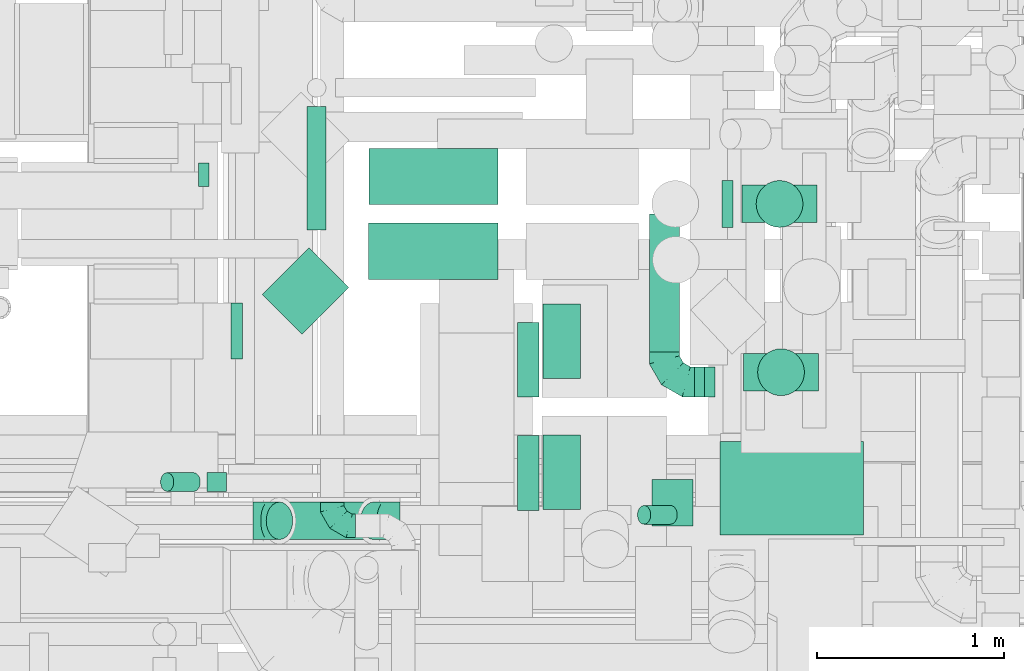
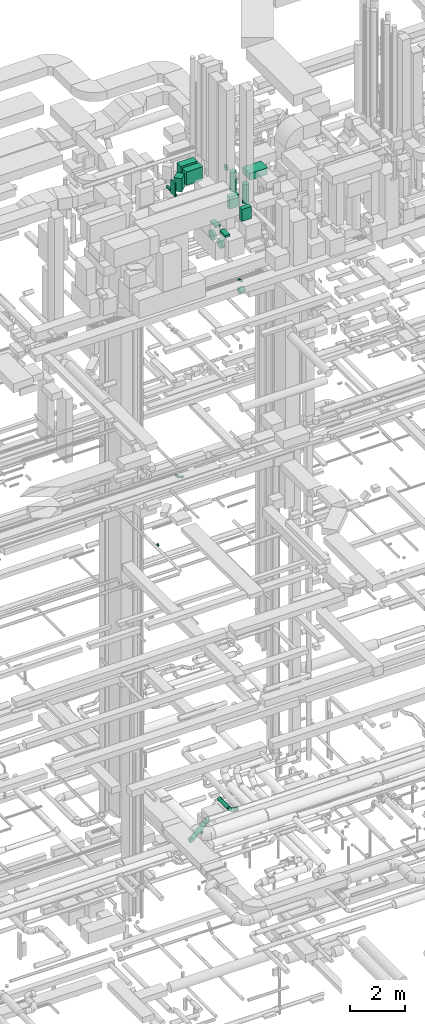
# One storey, part 181 of 337: 23 flow segments, 5 flow fittings.
"""IFC2X3 building model written with IfcOpenShell, lengths in millimetres."""

from ifc_helpers import new_model, entity, si_unit, converted_unit, derived_unit, direction, frame, origin, origin_2d_with_axis, place, context, subcontext, project, spatial, rectangle, circle, extrude, faceted_brep, source, transform, mapped, material, type_object, type_shapes, element, save


model = new_model("IFC2X3")

# Units and contexts
model_context = context("Model", 3, precision=0.01, world=origin(), true_north=direction((6.12303176911189e-17, 1.0)))
body_context = subcontext(model_context, "Body", "Model", "MODEL_VIEW")
ifc_project = project(units=[si_unit("LENGTHUNIT", "METRE", prefix="MILLI"), si_unit("AREAUNIT", "SQUARE_METRE"), si_unit("VOLUMEUNIT", "CUBIC_METRE"), converted_unit("PLANEANGLEUNIT", "DEGREE", entity("IfcRatioMeasure", 0.0174532925199433), si_unit("PLANEANGLEUNIT", "RADIAN"), dimensions=[0, 0, 0, 0, 0, 0, 0]), si_unit("MASSUNIT", "GRAM", prefix="KILO"), derived_unit("MASSDENSITYUNIT", [(si_unit("MASSUNIT", "GRAM", prefix="KILO"), 1), (si_unit("LENGTHUNIT", "METRE"), -3)]), derived_unit("MOMENTOFINERTIAUNIT", [(si_unit("LENGTHUNIT", "METRE"), 4)]), si_unit("TIMEUNIT", "SECOND"), si_unit("FREQUENCYUNIT", "HERTZ"), si_unit("THERMODYNAMICTEMPERATUREUNIT", "DEGREE_CELSIUS"), derived_unit("THERMALTRANSMITTANCEUNIT", [(si_unit("MASSUNIT", "GRAM", prefix="KILO"), 1), (si_unit("THERMODYNAMICTEMPERATUREUNIT", "KELVIN"), -1), (si_unit("TIMEUNIT", "SECOND"), -3)]), derived_unit("VOLUMETRICFLOWRATEUNIT", [(si_unit("LENGTHUNIT", "METRE"), 3), (si_unit("TIMEUNIT", "SECOND"), -1)]), derived_unit("MASSFLOWRATEUNIT", [(si_unit("MASSUNIT", "GRAM", prefix="KILO"), 1), (si_unit("TIMEUNIT", "SECOND"), -1)]), derived_unit("ROTATIONALFREQUENCYUNIT", [(si_unit("TIMEUNIT", "SECOND"), -1)]), si_unit("ELECTRICCURRENTUNIT", "AMPERE"), si_unit("ELECTRICVOLTAGEUNIT", "VOLT"), si_unit("POWERUNIT", "WATT"), si_unit("FORCEUNIT", "NEWTON", prefix="KILO"), si_unit("ILLUMINANCEUNIT", "LUX"), si_unit("LUMINOUSFLUXUNIT", "LUMEN"), si_unit("LUMINOUSINTENSITYUNIT", "CANDELA"), derived_unit("USERDEFINED", [(si_unit("MASSUNIT", "GRAM", prefix="KILO"), -1), (si_unit("LENGTHUNIT", "METRE"), -2), (si_unit("TIMEUNIT", "SECOND"), 3), (si_unit("LUMINOUSFLUXUNIT", "LUMEN"), 1)]), derived_unit("LINEARVELOCITYUNIT", [(si_unit("LENGTHUNIT", "METRE"), 1), (si_unit("TIMEUNIT", "SECOND"), -1)]), si_unit("PRESSUREUNIT", "PASCAL"), derived_unit("USERDEFINED", [(si_unit("LENGTHUNIT", "METRE"), -2), (si_unit("MASSUNIT", "GRAM", prefix="KILO"), 1), (si_unit("TIMEUNIT", "SECOND"), -2)]), derived_unit("LINEARFORCEUNIT", [(si_unit("MASSUNIT", "GRAM", prefix="KILO"), 1), (si_unit("LENGTHUNIT", "METRE"), 1), (si_unit("TIMEUNIT", "SECOND"), -2), (si_unit("LENGTHUNIT", "METRE"), -1)]), derived_unit("PLANARFORCEUNIT", [(si_unit("MASSUNIT", "GRAM", prefix="KILO"), 1), (si_unit("LENGTHUNIT", "METRE"), 1), (si_unit("TIMEUNIT", "SECOND"), -2), (si_unit("LENGTHUNIT", "METRE"), -2)])], contexts=[model_context])

# Site, building, storey
site_placement = place(None, origin())
site = spatial("IfcSite", under=ifc_project, at=site_placement, CompositionType="ELEMENT")
building_placement = place(site_placement, origin())
building = spatial("IfcBuilding", under=site, at=building_placement, CompositionType="ELEMENT")
storey_placement = place(building_placement, origin())
storey = spatial("IfcBuildingStorey", under=building, at=storey_placement, CompositionType="ELEMENT", Elevation=0.0)

# Flow segments
duct_segment_type_1 = type_object("IfcDuctSegmentType", PredefinedType="NOTDEFINED")
flow_segment_1_placement = place(storey_placement, frame((47380.36, 11539.6, 31100.0)))
element("IfcFlowSegment", 1, at=flow_segment_1_placement, inside=storey, type_object=duct_segment_type_1, context=body_context, shape_type="SweptSolid", body=[
    extrude(rectangle(XDim=689.677971288097, YDim=300.000000000001, at=origin_2d_with_axis()), frame((344.84, 150.0, 0.0), z_axis=(0.0, 0.0, 1.0), x_axis=(-1.0, 0.0, 0.0)), (0.0, 0.0, 1.0), 600.000000000002),
])
flow_segment_2_placement = place(storey_placement, frame((46812.3, 10846.41, 31100.0)))
element("IfcFlowSegment", 2, at=flow_segment_2_placement, inside=storey, type_object=duct_segment_type_1, context=body_context, shape_type="SweptSolid", body=[
    extrude(rectangle(XDim=352.512626584713, YDim=300.0, at=origin_2d_with_axis()), frame((230.7, 230.7, 0.0), z_axis=(0.0, 0.0, 1.0), x_axis=(-0.707106781186523, -0.707106781186572, 0.0)), (0.0, 0.0, 1.0), 600.000000000002),
])
flow_segment_3_placement = place(storey_placement, frame((46644.5, 10714.6, 31100.0)))
element("IfcFlowSegment", 3, at=flow_segment_3_placement, inside=storey, type_object=duct_segment_type_1, context=body_context, shape_type="SweptSolid", body=[
    extrude(rectangle(XDim=61.7324017095922, YDim=300.000000000001, at=origin_2d_with_axis()), frame((30.87, 150.0, 0.0), z_axis=(0.0, 0.0, 1.0), x_axis=(-1.0, 0.0, 0.0)), (0.0, 0.0, 1.0), 600.000000000002),
])
flow_segment_4_placement = place(storey_placement, frame((47379.76, 11139.6, 31100.0)))
element("IfcFlowSegment", 4, at=flow_segment_4_placement, inside=storey, type_object=duct_segment_type_1, context=body_context, shape_type="SweptSolid", body=[
    extrude(rectangle(XDim=690.269241288104, YDim=300.000000000001, at=origin_2d_with_axis()), frame((345.13, 150.0, 0.0)), (0.0, 0.0, 1.0), 600.000000000002),
])
for number, where in (
    (5, (48310.88, 9909.01, 29190.0)),
    (6, (48310.88, 10609.01, 29190.0)),
):
    element("IfcFlowSegment", number, at=place(storey_placement, frame(where)), inside=storey, type_object=duct_segment_type_1, context=body_context, shape_type="SweptSolid", body=[
        extrude(rectangle(XDim=200.000000000007, YDim=400.0, at=origin_2d_with_axis()), frame((100.0, 200.0, 0.0)), (0.0, 0.0, 1.0), 96.9999750006302),
    ])
flow_segment_5_placement = place(storey_placement, frame((49255.39, 9773.84, 31500.0)))
element("IfcFlowSegment", 7, at=flow_segment_5_placement, inside=storey, type_object=duct_segment_type_1, context=body_context, shape_type="SweptSolid", body=[
    extrude(rectangle(XDim=767.500000000033, YDim=500.000000000001, at=origin_2d_with_axis()), frame((383.75, 250.0, 0.0)), (0.0, 0.0, 1.0), 300.000000000001),
])
flow_segment_6_placement = place(storey_placement, frame((49374.88, 11442.75, 29150.0)))
element("IfcFlowSegment", 8, at=flow_segment_6_placement, inside=storey, type_object=duct_segment_type_1, context=body_context, shape_type="SweptSolid", body=[
    extrude(rectangle(XDim=200.0, YDim=400.000000000004, at=origin_2d_with_axis()), frame((200.0, 100.0, 0.0), z_axis=(0.0, 0.0, 1.0), x_axis=(0.0, -1.0, 0.0)), (0.0, 0.0, 1.0), 539.99999999999),
])
flow_segment_7_placement = place(storey_placement, frame((49382.71, 10543.71, 29150.0)))
element("IfcFlowSegment", 9, at=flow_segment_7_placement, inside=storey, type_object=duct_segment_type_1, context=body_context, shape_type="SweptSolid", body=[
    extrude(rectangle(XDim=199.999999999998, YDim=400.000000000004, at=origin_2d_with_axis()), frame((200.0, 100.0, 0.0), z_axis=(0.0, 0.0, 1.0), x_axis=(0.0, 1.0, 0.0)), (0.0, 0.0, 1.0), 539.99999999999),
])
duct_segment_type_2 = type_object("IfcDuctSegmentType", PredefinedType="NOTDEFINED")
flow_segment_8_placement = place(storey_placement, frame((46469.72, 11635.39, 14975.9)))
element("IfcFlowSegment", 10, at=flow_segment_8_placement, inside=storey, type_object=duct_segment_type_2, context=body_context, shape_type="SweptSolid", body=[
    extrude(circle(Radius=62.5, at=origin_2d_with_axis()), frame((0.0, 64.1, 64.1), z_axis=(1.0, 0.0, 0.0), x_axis=(0.0, -1.0, 0.0)), (0.0, 0.0, 1.0), 57.4999999999783),
])
flow_segment_9_placement = place(storey_placement, frame((46515.4, 10005.52, 18998.4)))
element("IfcFlowSegment", 11, at=flow_segment_9_placement, inside=storey, type_object=duct_segment_type_2, context=body_context, shape_type="SweptSolid", body=[
    extrude(circle(Radius=50.0, at=origin_2d_with_axis()), frame((0.0, 51.6, 51.6), z_axis=(1.0, 0.0, 0.0), x_axis=(0.0, 1.0, 0.0)), (0.0, 0.0, 1.0), 104.298646962705),
])
flow_segment_10_placement = place(storey_placement, frame((46266.31, 10005.52, 19042.34)))
element("IfcFlowSegment", 12, at=flow_segment_10_placement, inside=storey, type_object=duct_segment_type_2, context=body_context, shape_type="SweptSolid", body=[
    extrude(circle(Radius=50.0, at=origin_2d_with_axis()), frame((178.37, 51.6, 36.95), z_axis=(-0.707106781186544, 0.0, 0.707106781186551), x_axis=(0.0, 1.0, 0.0)), (0.0, 0.0, 1.0), 200.000000000003),
])
flow_segment_11_placement = place(storey_placement, frame((47050.05, 11402.74, 30551.83)))
element("IfcFlowSegment", 13, at=flow_segment_11_placement, inside=storey, type_object=duct_segment_type_2, context=body_context, shape_type="SweptSolid", body=[
    extrude(circle(Radius=50.0, at=origin_2d_with_axis()), frame((51.6, 0.0, 51.6), z_axis=(0.0, 1.0, 0.0), x_axis=(-1.0, 0.0, 0.0)), (0.0, 0.0, 1.0), 660.000000000015),
])
flow_segment_12_placement = place(storey_placement, frame((48175.03, 9903.56, 28658.02)))
element("IfcFlowSegment", 14, at=flow_segment_12_placement, inside=storey, type_object=duct_segment_type_2, context=body_context, shape_type="SweptSolid", body=[
    extrude(circle(Radius=200.0, at=origin_2d_with_axis()), frame((0.0, 201.6, 201.6), z_axis=(1.0, 0.0, 0.0), x_axis=(0.0, -1.0, 0.0)), (0.0, 0.0, 1.0), 115.84605999984),
])
flow_segment_13_placement = place(storey_placement, frame((48175.03, 10508.56, 28663.4)))
element("IfcFlowSegment", 15, at=flow_segment_13_placement, inside=storey, type_object=duct_segment_type_2, context=body_context, shape_type="SweptSolid", body=[
    extrude(circle(Radius=200.0, at=origin_2d_with_axis()), frame((0.0, 201.6, 201.6), z_axis=(1.0, 0.0, 0.0), x_axis=(0.0, 1.0, 0.0)), (0.0, 0.0, 1.0), 115.846059999866),
])
flow_segment_14_placement = place(storey_placement, frame((49267.58, 11416.15, 30873.4)))
element("IfcFlowSegment", 16, at=flow_segment_14_placement, inside=storey, type_object=duct_segment_type_2, context=body_context, shape_type="SweptSolid", body=[
    extrude(circle(Radius=125.0, at=origin_2d_with_axis()), frame((0.0, 126.6, 126.6), z_axis=(1.0, 0.0, 0.0), x_axis=(0.0, -1.0, 0.0)), (0.0, 0.0, 1.0), 57.2955599998903),
])
flow_segment_15_placement = place(storey_placement, frame((49448.28, 11416.15, 29890.0)))
element("IfcFlowSegment", 17, at=flow_segment_15_placement, inside=storey, type_object=duct_segment_type_2, context=body_context, shape_type="SweptSolid", body=[
    extrude(circle(Radius=125.0, at=origin_2d_with_axis()), frame((126.6, 126.6, 0.0), z_axis=(0.0, 0.0, 1.0), x_axis=(0.0, -1.0, 0.0)), (0.0, 0.0, 1.0), 860.000000000025),
])
flow_segment_16_placement = place(storey_placement, frame((49456.11, 10517.11, 29890.0)))
element("IfcFlowSegment", 18, at=flow_segment_16_placement, inside=storey, type_object=duct_segment_type_2, context=body_context, shape_type="SweptSolid", body=[
    extrude(circle(Radius=125.0, at=origin_2d_with_axis()), frame((126.6, 126.6, 0.0), z_axis=(0.0, 0.0, 1.0), x_axis=(0.0, 1.0, 0.0)), (0.0, 0.0, 1.0), 860.000000000012),
])
flow_segment_17_placement = place(storey_placement, frame((46831.06, 9748.4, 2886.27)))
element("IfcFlowSegment", 19, at=flow_segment_17_placement, inside=storey, type_object=duct_segment_type_2, context=body_context, shape_type="SweptSolid", body=[
    extrude(circle(Radius=100.0, at=origin_2d_with_axis()), frame((72.31, 101.6, 72.31), z_axis=(0.707106781186451, 0.0, 0.707106781186645), x_axis=(0.0, 1.0, 0.0)), (0.0, 0.0, 1.0), 711.126983721947),
])
flow_segment_18_placement = place(storey_placement, frame((48814.43, 9829.93, 26992.34)))
element("IfcFlowSegment", 20, at=flow_segment_18_placement, inside=storey, type_object=duct_segment_type_2, context=body_context, shape_type="SweptSolid", body=[
    extrude(circle(Radius=50.0, at=origin_2d_with_axis()), frame((178.37, 51.6, 36.95), z_axis=(-0.707106781186262, 0.0, 0.707106781186833), x_axis=(0.0, -1.0, 0.0)), (0.0, 0.0, 1.0), 199.999999999939),
])
flow_segment_19_placement = place(storey_placement, frame((49119.33, 10510.94, 2918.4)))
element("IfcFlowSegment", 21, at=flow_segment_19_placement, inside=storey, type_object=duct_segment_type_2, context=body_context, shape_type="SweptSolid", body=[
    extrude(circle(Radius=80.0, at=origin_2d_with_axis()), frame((0.0, 81.6, 81.6), z_axis=(1.0, 0.0, 0.0), x_axis=(0.0, -1.0, 0.0)), (0.0, 0.0, 1.0), 54.9998022966822),
])
flow_segment_20_placement = place(storey_placement, frame((48877.74, 10752.53, 2918.4)))
element("IfcFlowSegment", 22, at=flow_segment_20_placement, inside=storey, type_object=duct_segment_type_2, context=body_context, shape_type="SweptSolid", body=[
    extrude(circle(Radius=80.0, at=origin_2d_with_axis()), frame((81.6, 0.0, 81.6), z_axis=(0.0, 1.0, 0.0), x_axis=(1.0, 0.0, 0.0)), (0.0, 0.0, 1.0), 736.044812779233),
])
flow_segment_21_placement = place(storey_placement, frame((48892.33, 9819.63, 26473.4)))
element("IfcFlowSegment", 23, at=flow_segment_21_placement, inside=storey, type_object=duct_segment_type_2, context=body_context, shape_type="SweptSolid", body=[
    extrude(circle(Radius=125.0, at=origin_2d_with_axis()), frame((0.0, 126.6, 126.6), z_axis=(1.0, 0.0, 0.0), x_axis=(0.0, 1.0, 0.0)), (0.0, 0.0, 1.0), 218.994420697181),
])

# Flow fittings
ifc_material = material()
duct_fitting_type_1 = type_object("IfcDuctFittingType", PredefinedType="NOTDEFINED", material=ifc_material)
shared_shape_1 = source(origin(), body_context, "Body", "Brep", [
    faceted_brep([(-160.0, 0.0, -80.0), (-160.0, -20.71, -77.27), (-160.0, -40.0, -69.28), (-160.0, -56.57, -56.57), (-160.0, -69.28, -40.0), (-160.0, -77.27, -20.71), (-160.0, -80.0, 0.0), (-160.0, -77.27, 20.71), (-160.0, -69.28, 40.0), (-160.0, -56.57, 56.57), (-160.0, -40.0, 69.28), (-160.0, -20.71, 77.27), (-160.0, 0.0, 80.0), (-160.0, 20.71, 77.27), (-160.0, 40.0, 69.28), (-160.0, 56.57, 56.57), (-160.0, 69.28, 40.0), (-160.0, 77.27, 20.71), (-160.0, 80.0, 0.0), (-160.0, 77.27, -20.71), (-160.0, 69.28, -40.0), (-160.0, 56.57, -56.57), (-160.0, 40.0, -69.28), (-160.0, 20.71, -77.27), (-122.68, 20.71, 77.27), (-127.85, 40.0, 69.28), (-117.13, 0.0, 80.0), (-132.29, 56.57, 56.57), (-137.83, 77.27, 20.71), (-138.56, 80.0, 0.0), (-135.69, 69.28, 40.0), (-135.69, 69.28, -40.0), (-132.29, 56.57, -56.57), (-137.83, 77.27, -20.71), (-122.68, 20.71, -77.27), (-117.13, 0.0, -80.0), (-127.85, 40.0, -69.28), (-111.58, -20.71, -77.27), (-106.41, -40.0, -69.28), (-101.97, -56.57, -56.57), (-98.56, -69.28, -40.0), (-96.42, -77.27, -20.71), (-95.69, -80.0, 0.0), (-96.42, -77.27, 20.71), (-98.56, -69.28, 40.0), (-101.97, -56.57, 56.57), (-106.41, -40.0, 69.28), (-111.58, -20.71, 77.27), (-58.03, 58.03, 77.27), (-72.15, 72.15, 69.28), (-42.87, 42.87, 80.0), (-84.28, 84.28, 56.57), (-93.59, 93.59, 40.0), (-99.44, 99.44, 20.71), (-101.44, 101.44, 0.0), (-99.44, 99.44, -20.71), (-93.59, 93.59, -40.0), (-84.28, 84.28, -56.57), (-58.03, 58.03, -77.27), (-42.87, 42.87, -80.0), (-72.15, 72.15, -69.28), (-27.71, 27.71, -77.27), (-13.59, 13.59, -69.28), (-1.46, 1.46, -56.57), (7.85, -7.85, -40.0), (13.7, -13.7, -20.71), (15.69, -15.69, 0.0), (13.7, -13.7, 20.71), (7.85, -7.85, 40.0), (-1.46, 1.46, 56.57), (-13.59, 13.59, 69.28), (-27.71, 27.71, 77.27), (-20.71, 122.68, 77.27), (-40.0, 127.85, 69.28), (0.0, 117.13, 80.0), (-56.57, 132.29, 56.57), (-69.28, 135.69, 40.0), (-77.27, 137.83, 20.71), (-80.0, 138.56, 0.0), (-77.27, 137.83, -20.71), (-69.28, 135.69, -40.0), (-56.57, 132.29, -56.57), (-20.71, 122.68, -77.27), (0.0, 117.13, -80.0), (-40.0, 127.85, -69.28), (20.71, 111.58, -77.27), (40.0, 106.41, -69.28), (56.57, 101.97, -56.57), (69.28, 98.56, -40.0), (77.27, 96.42, -20.71), (80.0, 95.69, 0.0), (77.27, 96.42, 20.71), (69.28, 98.56, 40.0), (56.57, 101.97, 56.57), (40.0, 106.41, 69.28), (20.71, 111.58, 77.27), (-20.71, 160.0, -77.27), (-40.0, 160.0, -69.28), (-56.57, 160.0, -56.57), (-69.28, 160.0, -40.0), (-77.27, 160.0, -20.71), (-80.0, 160.0, 0.0), (-77.27, 160.0, 20.71), (-69.28, 160.0, 40.0), (-56.57, 160.0, 56.57), (-40.0, 160.0, 69.28), (-20.71, 160.0, 77.27), (0.0, 160.0, 80.0), (20.71, 160.0, 77.27), (40.0, 160.0, 69.28), (56.57, 160.0, 56.57), (69.28, 160.0, 40.0), (77.27, 160.0, 20.71), (80.0, 160.0, 0.0), (77.27, 160.0, -20.71), (69.28, 160.0, -40.0), (56.57, 160.0, -56.57), (40.0, 160.0, -69.28), (20.71, 160.0, -77.27), (0.0, 160.0, -80.0)], [[[0, 1, 2, 3, 4, 5, 6, 7, 8, 9, 10, 11, 12, 13, 14, 15, 16, 17, 18, 19, 20, 21, 22, 23]], [[24, 25, 14, 13]], [[26, 24, 13, 12]], [[14, 25, 27, 15]], [[28, 29, 18, 17]], [[30, 28, 17, 16]], [[15, 27, 30, 16]], [[20, 31, 32, 21]], [[33, 31, 20, 19]], [[18, 29, 33, 19]], [[34, 35, 0, 23]], [[36, 34, 23, 22]], [[32, 36, 22, 21]], [[1, 0, 35, 37]], [[2, 1, 37, 38]], [[3, 2, 38, 39]], [[5, 4, 40, 41]], [[6, 5, 41, 42]], [[39, 40, 4, 3]], [[6, 42, 43, 7]], [[7, 43, 44, 8]], [[8, 44, 45, 9]], [[9, 45, 46, 10]], [[10, 46, 47, 11]], [[26, 12, 11, 47]], [[48, 49, 25, 24]], [[50, 48, 24, 26]], [[27, 25, 49, 51]], [[52, 53, 28, 30]], [[51, 52, 30, 27]], [[29, 28, 53, 54]], [[55, 56, 31, 33]], [[54, 55, 33, 29]], [[32, 31, 56, 57]], [[58, 59, 35, 34]], [[60, 58, 34, 36]], [[57, 60, 36, 32]], [[37, 35, 59, 61]], [[38, 37, 61, 62]], [[39, 38, 62, 63]], [[41, 40, 64, 65]], [[42, 41, 65, 66]], [[63, 64, 40, 39]], [[43, 42, 66, 67]], [[44, 43, 67, 68]], [[68, 69, 45, 44]], [[46, 45, 69, 70]], [[47, 46, 70, 71]], [[26, 47, 71, 50]], [[72, 73, 49, 48]], [[74, 72, 48, 50]], [[51, 49, 73, 75]], [[76, 77, 53, 52]], [[75, 76, 52, 51]], [[54, 53, 77, 78]], [[79, 80, 56, 55]], [[78, 79, 55, 54]], [[57, 56, 80, 81]], [[82, 83, 59, 58]], [[84, 82, 58, 60]], [[81, 84, 60, 57]], [[61, 59, 83, 85]], [[62, 61, 85, 86]], [[63, 62, 86, 87]], [[65, 64, 88, 89]], [[66, 65, 89, 90]], [[87, 88, 64, 63]], [[67, 66, 90, 91]], [[68, 67, 91, 92]], [[92, 93, 69, 68]], [[70, 69, 93, 94]], [[71, 70, 94, 95]], [[50, 71, 95, 74]], [[96, 97, 98, 99, 100, 101, 102, 103, 104, 105, 106, 107, 108, 109, 110, 111, 112, 113, 114, 115, 116, 117, 118, 119]], [[72, 74, 107, 106]], [[73, 72, 106, 105]], [[75, 73, 105, 104]], [[77, 76, 103, 102]], [[78, 77, 102, 101]], [[75, 104, 103, 76]], [[78, 101, 100, 79]], [[79, 100, 99, 80]], [[80, 99, 98, 81]], [[84, 97, 96, 82]], [[82, 96, 119, 83]], [[84, 81, 98, 97]], [[118, 117, 86, 85]], [[119, 118, 85, 83]], [[116, 87, 86, 117]], [[88, 115, 114, 89]], [[89, 114, 113, 90]], [[115, 88, 87, 116]], [[112, 111, 92, 91]], [[113, 112, 91, 90]], [[111, 110, 93, 92]], [[95, 94, 109, 108]], [[74, 95, 108, 107]], [[110, 109, 94, 93]]]),
])
type_shapes(duct_fitting_type_1, [shared_shape_1])
flow_fitting_1_placement = place(storey_placement, frame((48959.33, 10592.53, 3000.0), z_axis=(0.0, 0.0, 1.0), x_axis=(0.0, -1.0, 0.0)))
element("IfcFlowFitting", 24, at=flow_fitting_1_placement, inside=storey, type_object=duct_fitting_type_1, material=ifc_material, context=body_context, shape_type="MappedRepresentation", body=[
    mapped(shared_shape_1, transform((0.0, 0.0, 0.0), scale=1.0)),
])
duct_fitting_type_2 = type_object("IfcDuctFittingType", PredefinedType="NOTDEFINED", material=ifc_material)
shared_shape_2 = source(origin(), body_context, "Body", "Brep", [
    faceted_brep([(-125.0, 0.0, -62.5), (-125.0, -16.18, -60.37), (-125.0, -31.25, -54.13), (-125.0, -44.19, -44.19), (-125.0, -54.13, -31.25), (-125.0, -60.37, -16.18), (-125.0, -62.5, 0.0), (-125.0, -60.37, 16.18), (-125.0, -54.13, 31.25), (-125.0, -44.19, 44.19), (-125.0, -31.25, 54.13), (-125.0, -16.18, 60.37), (-125.0, 0.0, 62.5), (-125.0, 16.18, 60.37), (-125.0, 31.25, 54.13), (-125.0, 44.19, 44.19), (-125.0, 54.13, 31.25), (-125.0, 60.37, 16.18), (-125.0, 62.5, 0.0), (-125.0, 60.37, -16.18), (-125.0, 54.13, -31.25), (-125.0, 44.19, -44.19), (-125.0, 31.25, -54.13), (-125.0, 16.18, -60.37), (-95.84, 16.18, 60.37), (-99.88, 31.25, 54.13), (-91.51, 0.0, 62.5), (-103.35, 44.19, 44.19), (-107.68, 60.37, 16.18), (-108.25, 62.5, 0.0), (-106.01, 54.13, 31.25), (-106.01, 54.13, -31.25), (-103.35, 44.19, -44.19), (-107.68, 60.37, -16.18), (-95.84, 16.18, -60.37), (-91.51, 0.0, -62.5), (-99.88, 31.25, -54.13), (-87.17, -16.18, -60.37), (-83.13, -31.25, -54.13), (-79.66, -44.19, -44.19), (-77.0, -54.13, -31.25), (-75.33, -60.37, -16.18), (-74.76, -62.5, 0.0), (-75.33, -60.37, 16.18), (-77.0, -54.13, 31.25), (-79.66, -44.19, 44.19), (-83.13, -31.25, 54.13), (-87.17, -16.18, 60.37), (-45.34, 45.34, 60.37), (-56.37, 56.37, 54.13), (-33.49, 33.49, 62.5), (-65.85, 65.85, 44.19), (-73.12, 73.12, 31.25), (-77.69, 77.69, 16.18), (-79.25, 79.25, 0.0), (-77.69, 77.69, -16.18), (-73.12, 73.12, -31.25), (-65.85, 65.85, -44.19), (-45.34, 45.34, -60.37), (-33.49, 33.49, -62.5), (-56.37, 56.37, -54.13), (-21.65, 21.65, -60.37), (-10.62, 10.62, -54.13), (-1.14, 1.14, -44.19), (6.13, -6.13, -31.25), (10.7, -10.7, -16.18), (12.26, -12.26, 0.0), (10.7, -10.7, 16.18), (6.13, -6.13, 31.25), (-1.14, 1.14, 44.19), (-10.62, 10.62, 54.13), (-21.65, 21.65, 60.37), (-16.18, 95.84, 60.37), (-31.25, 99.88, 54.13), (0.0, 91.51, 62.5), (-44.19, 103.35, 44.19), (-54.13, 106.01, 31.25), (-60.37, 107.68, 16.18), (-62.5, 108.25, 0.0), (-60.37, 107.68, -16.18), (-54.13, 106.01, -31.25), (-44.19, 103.35, -44.19), (-16.18, 95.84, -60.37), (0.0, 91.51, -62.5), (-31.25, 99.88, -54.13), (16.18, 87.17, -60.37), (31.25, 83.13, -54.13), (44.19, 79.66, -44.19), (54.13, 77.0, -31.25), (60.37, 75.33, -16.18), (62.5, 74.76, 0.0), (60.37, 75.33, 16.18), (54.13, 77.0, 31.25), (44.19, 79.66, 44.19), (31.25, 83.13, 54.13), (16.18, 87.17, 60.37), (-16.18, 125.0, -60.37), (-31.25, 125.0, -54.13), (-44.19, 125.0, -44.19), (-54.13, 125.0, -31.25), (-60.37, 125.0, -16.18), (-62.5, 125.0, 0.0), (-60.37, 125.0, 16.18), (-54.13, 125.0, 31.25), (-44.19, 125.0, 44.19), (-31.25, 125.0, 54.13), (-16.18, 125.0, 60.37), (0.0, 125.0, 62.5), (16.18, 125.0, 60.37), (31.25, 125.0, 54.13), (44.19, 125.0, 44.19), (54.13, 125.0, 31.25), (60.37, 125.0, 16.18), (62.5, 125.0, 0.0), (60.37, 125.0, -16.18), (54.13, 125.0, -31.25), (44.19, 125.0, -44.19), (31.25, 125.0, -54.13), (16.18, 125.0, -60.37), (0.0, 125.0, -62.5)], [[[0, 1, 2, 3, 4, 5, 6, 7, 8, 9, 10, 11, 12, 13, 14, 15, 16, 17, 18, 19, 20, 21, 22, 23]], [[24, 25, 14, 13]], [[26, 24, 13, 12]], [[14, 25, 27, 15]], [[28, 29, 18, 17]], [[30, 28, 17, 16]], [[15, 27, 30, 16]], [[20, 31, 32, 21]], [[33, 31, 20, 19]], [[18, 29, 33, 19]], [[34, 35, 0, 23]], [[36, 34, 23, 22]], [[21, 32, 36, 22]], [[1, 0, 35, 37]], [[2, 1, 37, 38]], [[38, 39, 3, 2]], [[5, 4, 40, 41]], [[6, 5, 41, 42]], [[39, 40, 4, 3]], [[6, 42, 43, 7]], [[7, 43, 44, 8]], [[45, 9, 8, 44]], [[9, 45, 46, 10]], [[10, 46, 47, 11]], [[26, 12, 11, 47]], [[48, 49, 25, 24]], [[50, 48, 24, 26]], [[27, 25, 49, 51]], [[52, 53, 28, 30]], [[51, 52, 30, 27]], [[29, 28, 53, 54]], [[55, 56, 31, 33]], [[54, 55, 33, 29]], [[57, 32, 31, 56]], [[58, 59, 35, 34]], [[60, 58, 34, 36]], [[57, 60, 36, 32]], [[37, 35, 59, 61]], [[38, 37, 61, 62]], [[39, 38, 62, 63]], [[41, 40, 64, 65]], [[42, 41, 65, 66]], [[63, 64, 40, 39]], [[43, 42, 66, 67]], [[44, 43, 67, 68]], [[68, 69, 45, 44]], [[46, 45, 69, 70]], [[47, 46, 70, 71]], [[26, 47, 71, 50]], [[72, 73, 49, 48]], [[74, 72, 48, 50]], [[51, 49, 73, 75]], [[76, 77, 53, 52]], [[75, 76, 52, 51]], [[54, 53, 77, 78]], [[79, 80, 56, 55]], [[78, 79, 55, 54]], [[81, 57, 56, 80]], [[82, 83, 59, 58]], [[84, 82, 58, 60]], [[81, 84, 60, 57]], [[61, 59, 83, 85]], [[62, 61, 85, 86]], [[63, 62, 86, 87]], [[65, 64, 88, 89]], [[66, 65, 89, 90]], [[87, 88, 64, 63]], [[67, 66, 90, 91]], [[68, 67, 91, 92]], [[92, 93, 69, 68]], [[70, 69, 93, 94]], [[71, 70, 94, 95]], [[50, 71, 95, 74]], [[96, 97, 98, 99, 100, 101, 102, 103, 104, 105, 106, 107, 108, 109, 110, 111, 112, 113, 114, 115, 116, 117, 118, 119]], [[72, 74, 107, 106]], [[73, 72, 106, 105]], [[75, 73, 105, 104]], [[77, 76, 103, 102]], [[78, 77, 102, 101]], [[75, 104, 103, 76]], [[78, 101, 100, 79]], [[79, 100, 99, 80]], [[80, 99, 98, 81]], [[96, 119, 83, 82]], [[97, 96, 82, 84]], [[84, 81, 98, 97]], [[83, 119, 118, 85]], [[85, 118, 117, 86]], [[116, 87, 86, 117]], [[88, 115, 114, 89]], [[89, 114, 113, 90]], [[115, 88, 87, 116]], [[91, 90, 113, 112]], [[92, 91, 112, 111]], [[111, 110, 93, 92]], [[95, 94, 109, 108]], [[74, 95, 108, 107]], [[110, 109, 94, 93]]]),
])
type_shapes(duct_fitting_type_2, [shared_shape_2])
flow_fitting_2_placement = place(storey_placement, frame((47184.59, 9822.51, 3100.0), z_axis=(0.0, 0.0, 1.0), x_axis=(0.0, -1.0, 0.0)))
element("IfcFlowFitting", 25, at=flow_fitting_2_placement, inside=storey, type_object=duct_fitting_type_2, material=ifc_material, context=body_context, shape_type="MappedRepresentation", body=[
    mapped(shared_shape_2, transform((0.0, 0.0, 0.0), scale=1.0)),
])
duct_fitting_type_3 = type_object("IfcDuctFittingType", PredefinedType="NOTDEFINED", material=ifc_material)
shared_shape_3 = source(origin(), body_context, "Body", "Brep", [
    faceted_brep([(-82.84, 0.0, -100.0), (-82.84, -25.88, -96.59), (-82.84, -50.0, -86.6), (-82.84, -70.71, -70.71), (-82.84, -86.6, -50.0), (-82.84, -96.59, -25.88), (-82.84, -100.0, 0.0), (-82.84, -96.59, 25.88), (-82.84, -86.6, 50.0), (-82.84, -70.71, 70.71), (-82.84, -50.0, 86.6), (-82.84, -25.88, 96.59), (-82.84, 0.0, 100.0), (-82.84, 25.88, 96.59), (-82.84, 50.0, 86.6), (-82.84, 70.71, 70.71), (-82.84, 86.6, 50.0), (-82.84, 96.59, 25.88), (-82.84, 100.0, 0.0), (-82.84, 96.59, -25.88), (-82.84, 86.6, -50.0), (-82.84, 70.71, -70.71), (-82.84, 50.0, -86.6), (-82.84, 25.88, -96.59), (-10.72, 25.88, 96.59), (-20.71, 50.0, 86.6), (0.0, 0.0, 100.0), (-29.29, 70.71, 70.71), (-35.87, 86.6, 50.0), (-40.01, 96.59, 25.88), (-41.42, 100.0, 0.0), (-40.01, 96.59, -25.88), (-35.87, 86.6, -50.0), (-29.29, 70.71, -70.71), (-10.72, 25.88, -96.59), (0.0, 0.0, -100.0), (-20.71, 50.0, -86.6), (10.72, -25.88, -96.59), (20.71, -50.0, -86.6), (29.29, -70.71, -70.71), (35.87, -86.6, -50.0), (40.01, -96.59, -25.88), (41.42, -100.0, 0.0), (40.01, -96.59, 25.88), (35.87, -86.6, 50.0), (29.29, -70.71, 70.71), (20.71, -50.0, 86.6), (10.72, -25.88, 96.59), (58.58, 58.58, 100.0), (40.28, 76.88, 96.59), (23.22, 93.93, 86.6), (8.58, 108.58, 70.71), (-2.66, 119.82, 50.0), (-9.72, 126.88, 25.88), (-12.13, 129.29, 0.0), (-9.72, 126.88, -25.88), (-2.66, 119.82, -50.0), (8.58, 108.58, -70.71), (23.22, 93.93, -86.6), (40.28, 76.88, -96.59), (58.58, 58.58, -100.0), (76.88, 40.28, -96.59), (93.93, 23.22, -86.6), (108.58, 8.58, -70.71), (119.82, -2.66, -50.0), (126.88, -9.72, -25.88), (129.29, -12.13, 0.0), (126.88, -9.72, 25.88), (119.82, -2.66, 50.0), (108.58, 8.58, 70.71), (93.93, 23.22, 86.6), (76.88, 40.28, 96.59)], [[[0, 1, 2, 3, 4, 5, 6, 7, 8, 9, 10, 11, 12, 13, 14, 15, 16, 17, 18, 19, 20, 21, 22, 23]], [[24, 25, 14, 13]], [[26, 24, 13, 12]], [[14, 25, 27, 15]], [[28, 29, 17, 16]], [[28, 16, 15, 27]], [[30, 18, 17, 29]], [[31, 32, 20, 19]], [[30, 31, 19, 18]], [[32, 33, 21, 20]], [[34, 35, 0, 23]], [[36, 34, 23, 22]], [[33, 36, 22, 21]], [[1, 0, 35, 37]], [[2, 1, 37, 38]], [[38, 39, 3, 2]], [[5, 4, 40, 41]], [[6, 5, 41, 42]], [[39, 40, 4, 3]], [[6, 42, 43, 7]], [[7, 43, 44, 8]], [[8, 44, 45, 9]], [[9, 45, 46, 10]], [[10, 46, 47, 11]], [[26, 12, 11, 47]], [[24, 26, 48, 49]], [[25, 24, 49, 50]], [[27, 25, 50, 51]], [[29, 28, 52, 53]], [[30, 29, 53, 54]], [[51, 52, 28, 27]], [[30, 54, 55, 31]], [[31, 55, 56, 32]], [[57, 33, 32, 56]], [[36, 58, 59, 34]], [[34, 59, 60, 35]], [[58, 36, 33, 57]], [[35, 60, 61, 37]], [[37, 61, 62, 38]], [[63, 39, 38, 62]], [[40, 64, 65, 41]], [[41, 65, 66, 42]], [[64, 40, 39, 63]], [[43, 42, 66, 67]], [[44, 43, 67, 68]], [[68, 69, 45, 44]], [[47, 46, 70, 71]], [[26, 47, 71, 48]], [[69, 70, 46, 45]], [[59, 58, 57, 56, 55, 54, 53, 52, 51, 50, 49, 48, 71, 70, 69, 68, 67, 66, 65, 64, 63, 62, 61, 60]]]),
])
type_shapes(duct_fitting_type_3, [shared_shape_3])
for number, where, z_axis, x_axis in (
    (26, (46844.79, 9850.0, 2900.0), (0.0, 1.0, 0.0), (-0.707106781186455, 0.0, -0.70710678118664)),
    (27, (47464.79, 9850.0, 3520.0), (0.0, 1.0, 0.0), (0.707106781186459, 0.0, 0.707106781186637)),
):
    element("IfcFlowFitting", number, at=place(storey_placement, frame(where, z_axis=z_axis, x_axis=x_axis)), inside=storey, type_object=duct_fitting_type_3, material=ifc_material, context=body_context, shape_type="MappedRepresentation", body=[
        mapped(shared_shape_3, transform((0.0, 0.0, 0.0), scale=1.0)),
    ])
duct_fitting_type_4 = type_object("IfcDuctFittingType", PredefinedType="NOTDEFINED", material=ifc_material)
shared_shape_4 = source(origin(), body_context, "Body", "Brep", [
    faceted_brep([(20.0, 0.0, -80.0), (20.0, 20.71, -77.27), (20.0, 40.0, -69.28), (20.0, 56.57, -56.57), (20.0, 69.28, -40.0), (20.0, 77.27, -20.71), (20.0, 80.0, 0.0), (20.0, 77.27, 20.71), (20.0, 69.28, 40.0), (20.0, 56.57, 56.57), (20.0, 40.0, 69.28), (20.0, 20.71, 77.27), (20.0, 0.0, 80.0), (20.0, -20.71, 77.27), (20.0, -40.0, 69.28), (20.0, -56.57, 56.57), (20.0, -69.28, 40.0), (20.0, -77.27, 20.71), (20.0, -80.0, 0.0), (20.0, -77.27, -20.71), (20.0, -69.28, -40.0), (20.0, -56.57, -56.57), (20.0, -40.0, -69.28), (20.0, -20.71, -77.27), (0.0, 0.0, 80.0), (-35.05, 0.0, 80.0), (-35.05, -20.71, 77.27), (0.0, -20.71, 77.27), (-35.05, -40.0, 69.28), (0.0, -40.0, 69.28), (0.0, -56.57, 56.57), (-35.05, -56.57, 56.57), (0.0, -69.28, 40.0), (-35.05, -69.28, 40.0), (-35.05, -77.27, 20.71), (0.0, -77.27, 20.71), (-35.05, -80.0, 0.0), (0.0, -80.0, 0.0), (-35.05, -77.27, -20.71), (0.0, -77.27, -20.71), (-35.05, -69.28, -40.0), (0.0, -69.28, -40.0), (0.0, -56.57, -56.57), (-35.05, -56.57, -56.57), (0.0, -40.0, -69.28), (-35.05, -40.0, -69.28), (-35.05, -20.71, -77.27), (0.0, -20.71, -77.27), (-35.05, 0.0, -80.0), (0.0, 0.0, -80.0), (-35.05, 20.71, -77.27), (0.0, 20.71, -77.27), (-35.05, 40.0, -69.28), (0.0, 40.0, -69.28), (0.0, 56.57, -56.57), (-35.05, 56.57, -56.57), (0.0, 69.28, -40.0), (-35.05, 69.28, -40.0), (-35.05, 77.27, -20.71), (0.0, 77.27, -20.71), (-35.05, 80.0, 0.0), (0.0, 80.0, 0.0), (-35.05, 77.27, 20.71), (0.0, 77.27, 20.71), (-35.05, 69.28, 40.0), (0.0, 69.28, 40.0), (0.0, 56.57, 56.57), (-35.05, 56.57, 56.57), (0.0, 40.0, 69.28), (-35.05, 40.0, 69.28), (-35.05, 20.71, 77.27), (0.0, 20.71, 77.27)], [[[0, 1, 2, 3, 4, 5, 6, 7, 8, 9, 10, 11, 12, 13, 14, 15, 16, 17, 18, 19, 20, 21, 22, 23]], [[13, 12, 24, 25, 26, 27]], [[14, 13, 27, 26, 28, 29]], [[30, 15, 14, 29, 28, 31]], [[17, 16, 32, 33, 34, 35]], [[18, 17, 35, 34, 36, 37]], [[32, 16, 15, 30, 31, 33]], [[19, 18, 37, 36, 38, 39]], [[20, 19, 39, 38, 40, 41]], [[42, 21, 20, 41, 40, 43]], [[23, 22, 44, 45, 46, 47]], [[0, 23, 47, 46, 48, 49]], [[44, 22, 21, 42, 43, 45]], [[1, 0, 49, 48, 50, 51]], [[2, 1, 51, 50, 52, 53]], [[54, 3, 2, 53, 52, 55]], [[5, 4, 56, 57, 58, 59]], [[6, 5, 59, 58, 60, 61]], [[56, 4, 3, 54, 55, 57]], [[7, 6, 61, 60, 62, 63]], [[8, 7, 63, 62, 64, 65]], [[66, 9, 8, 65, 64, 67]], [[11, 10, 68, 69, 70, 71]], [[12, 11, 71, 70, 25, 24]], [[68, 10, 9, 66, 67, 69]], [[46, 45, 43, 40, 38, 36, 34, 33, 31, 28, 26, 25, 70, 69, 67, 64, 62, 60, 58, 57, 55, 52, 50, 48]]]),
])
type_shapes(duct_fitting_type_4, [shared_shape_4])
flow_fitting_3_placement = place(storey_placement, frame((49194.33, 10592.53, 3000.0), z_axis=(0.0, 0.0, -1.0), x_axis=(-1.0, 0.0, 0.0)))
element("IfcFlowFitting", 28, at=flow_fitting_3_placement, inside=storey, type_object=duct_fitting_type_4, material=ifc_material, context=body_context, shape_type="MappedRepresentation", body=[
    mapped(shared_shape_4, transform((0.0, 0.0, 0.0), scale=1.0)),
])

save(model, "model.ifc")
